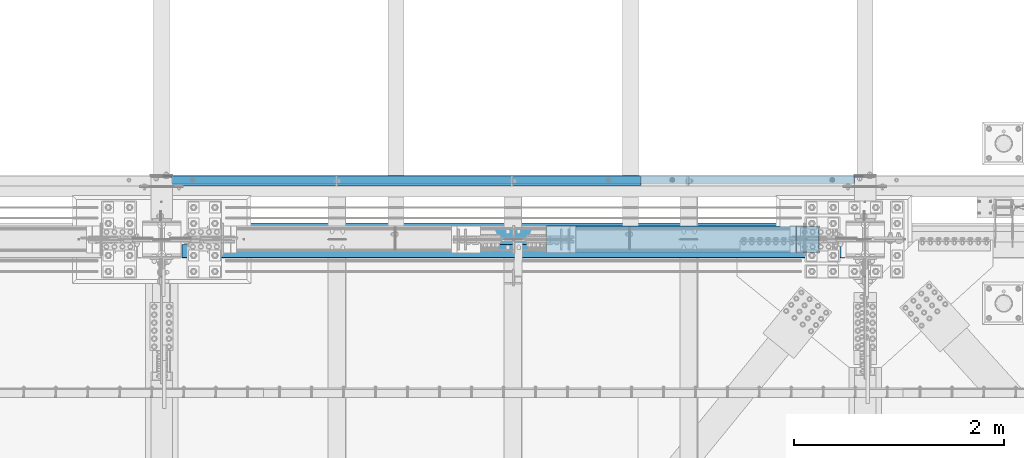
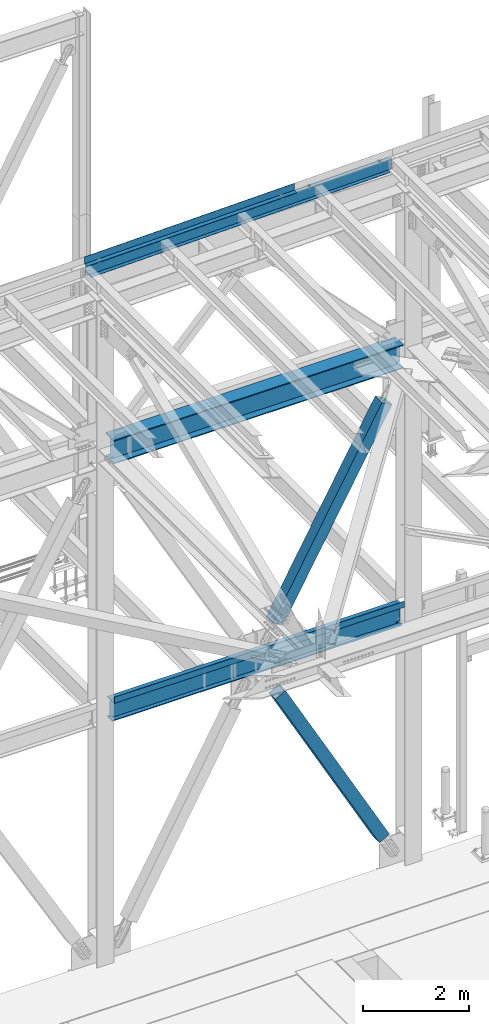
# One storey, part 1919 of 3843: 5 beams, 2 members, 5 elements without a shape of their own.
"""IFC2X3 building model written with IfcOpenShell, lengths in millimetres."""

from ifc_helpers import new_model, si_unit, frame, origin_with_axes, place, context, subcontext, project, spatial, faceted_brep, material, type_object, element, aggregate, save


model = new_model("IFC2X3")

# Units and contexts
model_context = context("Model", 3, precision=1e-05, world=origin_with_axes())
body_context = subcontext(model_context, "Body", "Model", "MODEL_VIEW")
ifc_project = project(units=[si_unit("LENGTHUNIT", "METRE", prefix="MILLI"), si_unit("AREAUNIT", "SQUARE_METRE"), si_unit("VOLUMEUNIT", "CUBIC_METRE"), si_unit("MASSUNIT", "GRAM", prefix="KILO"), si_unit("TIMEUNIT", "SECOND"), si_unit("PLANEANGLEUNIT", "RADIAN"), si_unit("SOLIDANGLEUNIT", "STERADIAN"), si_unit("THERMODYNAMICTEMPERATUREUNIT", "DEGREE_CELSIUS"), si_unit("LUMINOUSINTENSITYUNIT", "LUMEN")], contexts=[model_context])

# Site, building, storey
site_placement = place(None, origin_with_axes())
site = spatial("IfcSite", under=ifc_project, at=site_placement, CompositionType="ELEMENT")
building_placement = place(site_placement, origin_with_axes())
building = spatial("IfcBuilding", under=site, at=building_placement, Name="Undefined", CompositionType="ELEMENT")
storey_placement = place(building_placement, origin_with_axes())
storey = spatial("IfcBuildingStorey", under=building, at=storey_placement, Name="Undefined", CompositionType="ELEMENT", Elevation=0.0)

# Assembly, beams
assembly_1_placement = place(storey_placement, origin_with_axes())
assembly_1 = element("IfcElementAssembly", 1, at=assembly_1_placement, inside=storey, Name="CHANNEL", AssemblyPlace="NOTDEFINED", PredefinedType="RIGID_FRAME")
ifc_material_1 = material(Name="STEEL/A572-50")
beam_type_1 = type_object("IfcBeamType", Name="C12X20.7", PredefinedType="NOTDEFINED")
beam_1_placement = place(assembly_1_placement, frame((55927.4421007535, 92786.199998456, 45986.575723427), z_axis=(-0.0211520980073474, 0.0, 0.999776269347241), x_axis=(0.999776270257024, 0.0, 0.0211520550054619)))
beam_1 = element("IfcBeam", 2, at=beam_1_placement, type_object=beam_type_1, material=ifc_material_1, Name="CHANNEL", ObjectType="C12X20.7", context=body_context, shape_type="Brep", body=[
    faceted_brep([(15.8751814754869, 30.1625000000058, -127.000000049156), (15.8750003662499, 38.1000000000058, -127.000000023749), (85.725000532555, 38.1000000000058, -127.000000023691), (85.725000532555, 30.1625000000058, -127.000000023691), (90.5850800505723, 38.1000000000058, -127.966729946267), (90.5850800505723, 30.1625000000058, -127.966729946267), (94.7052565187187, 38.1000000000058, -130.719743846734), (94.7052565187187, 30.1625000000058, -130.719743846734), (97.4582704191853, 38.1000000000058, -134.839920314858), (97.458270419178, 30.1625000000058, -134.674927499669), (98.4250003417692, 1.00112811196595e-06, -139.699999832876), (98.4250003417692, 38.1000000000058, -139.699999832876), (98.4250003417837, 38.1000000000058, -152.399999999638), (98.4250003417837, -38.1000000000058, -152.399999999638), (98.4250003417765, -38.1000000000058, -146.047459999652), (6608.67788717964, -38.1000000000058, 146.047460006397), (6608.67788717963, -38.1000000000058, 152.400000006382), (98.4250003414782, -38.1000000000058, 152.399999999863), (98.4250003414927, -38.1000000000058, 146.047459999871), (6608.67788717963, 38.1000000000058, 152.400000006382), (98.4250003414782, 38.1000000000058, 152.399999999863), (85.7250005323076, 30.1625000000058, 126.99999997508), (85.7250005323076, 38.1000000000058, 126.99999997508), (15.8750006201954, 38.1000000000058, 126.999999975014), (15.8751845281877, 30.1625000000058, 126.999999949614), (90.5850800503176, 30.1625000000058, 127.966729897671), (90.5850800503176, 38.1000000000058, 127.966729897671), (94.7052565184495, 30.1625000000058, 130.719743798138), (94.7052565184495, 38.1000000000058, 130.719743798138), (97.4582704189161, 30.1625000000058, 134.674927499887), (97.4582704189233, 38.1000000000058, 134.839920266269), (98.4250003414927, 1.29402906168252e-06, 139.699999784301), (98.4250003414927, 38.1000000000058, 139.699999784301), (6609.64461710223, 30.1625000000058, 134.674927506407), (6608.67788717964, 1.15988950710744e-06, 139.699999813165), (6608.67788717964, 38.1000000000058, 139.699999813165), (6609.64461710223, 38.1000000000058, 134.83992029514), (6612.39763100271, 30.1625000000058, 130.719743827016), (6612.39763100271, 38.1000000000058, 130.719743827016), (6616.51780747084, 30.1625000000058, 127.966729926549), (6616.51780747084, 38.1000000000058, 127.966729926549), (6621.37788698886, 30.1625000000058, 127.00000000398), (6621.37788698886, 38.1000000000058, 127.00000000398), (6691.22583270017, 30.1625000000058, 127.000000004038), (6691.22559387093, 38.1000000000058, 127.000000004038), (6691.22583243326, 30.1625000000058, 114.299999315597), (6691.22582758687, 30.1625000000058, -116.300000677649), (6691.22582736199, 30.1625000000058, -126.999999994725), (6691.22558853275, 38.1000000000058, -126.999999994725), (6621.37788698912, 30.1625000000058, -126.999999994805), (6621.37788698912, 38.1000000000058, -126.999999994805), (6616.51780747109, 30.1625000000058, -127.966729917382), (6616.51780747109, 38.1000000000058, -127.966729917382), (6612.39763100295, 30.1625000000058, -130.719743817848), (6612.39763100295, 38.1000000000058, -130.719743817848), (6609.64461710249, 30.1625000000058, -134.674927493157), (6609.64461710249, 38.1000000000058, -134.839920285995), (6608.67788717993, 1.13523856271058e-06, -139.699999804012), (6608.67788717993, 38.1000000000058, -139.699999804012), (6608.67788717993, -38.1000000000058, -146.047459993133), (6608.67788717994, -38.1000000000058, -152.399999993126), (6608.67788717994, 38.1000000000058, -152.399999993126), (15.8751816040894, 30.1625000000058, -116.299999637456), (15.8751843755526, 30.1625000000058, 114.300000367155)], [[[0, 1, 2, 3]], [[3, 2, 4, 5]], [[5, 4, 6, 7]], [[7, 6, 8, 9]], [[10, 11, 12, 13, 14]], [[9, 8, 11, 10]], [[15, 16, 17, 18]], [[16, 19, 20, 17]], [[21, 22, 23, 24]], [[25, 26, 22, 21]], [[27, 28, 26, 25]], [[29, 30, 28, 27]], [[31, 32, 30, 29]], [[17, 20, 32, 31, 18]], [[29, 33, 34, 15, 18, 31]], [[16, 15, 34, 35, 19]], [[33, 36, 35, 34]], [[37, 38, 36, 33]], [[39, 40, 38, 37]], [[41, 42, 40, 39]], [[43, 44, 42, 41]], [[44, 43, 45, 46, 47, 48]], [[47, 49, 50, 48]], [[51, 52, 50, 49]], [[53, 54, 52, 51]], [[55, 56, 54, 53]], [[57, 58, 56, 55]], [[59, 60, 61, 58, 57]], [[60, 59, 14, 13]], [[61, 60, 13, 12]], [[6, 4, 2, 1, 23, 22, 26, 28, 30, 32, 20, 19, 35, 36, 38, 40, 42, 44, 48, 50, 52, 54, 56, 58, 61, 12, 11, 8]], [[62, 63, 24, 23, 1, 0]], [[55, 53, 51, 49, 47, 46, 45, 43, 41, 39, 37, 33, 29, 27, 25, 21, 24, 63, 62, 0, 3, 5, 7, 9]], [[59, 57, 55, 9, 10, 14]]]),
])
ifc_material_2 = material(Name="STEEL/A36")
beam_type_2 = type_object("IfcBeamType", PredefinedType="NOTDEFINED")
beam_2_placement = place(assembly_1_placement, frame((58209.6399109012, 92722.6999533711, 46190.469612909), z_axis=(0.999776270257024, 0.0, 0.0211520550054619), x_axis=(0.0, 1.0, 0.0)))
beam_2 = element("IfcBeam", 3, at=beam_2_placement, type_object=beam_type_2, material=ifc_material_2, Name="BENT_PLATE", context=body_context, shape_type="Brep", body=[
    faceted_brep([(0.0, 0.0, -2286.0), (3.49245965480804e-10, 3.17499999771098, -2282.82500002157), (95.2499986609328, 3.17500004237809, -2282.82500002194), (98.4249986544455, 9.08548827283084e-08, -2285.99999999666), (95.249998597661, 161.925001390824, -2282.82500002276), (98.4249985899223, 161.92500139217, -2285.99999999706), (95.2499986633193, 3.17500004695466, 2285.99999999594), (95.2499985934701, 161.925001402509, 2285.99999999556), (5.82076609134674e-11, -3.17499999999563, -2286.0), (5.82076609134674e-11, -3.17499999999563, 2286.0), (-4.36557456851006e-11, 3.17499999998836, 2286.0), (101.599998662903, -3.17499995464459, -2285.99999999667), (101.600001545667, -3.17499906016019, 2285.99999999734), (101.599998593476, 161.925001405216, 2285.99999999553), (101.599998596852, 161.925001394004, -2285.99999999707)], [[[0, 1, 2, 3]], [[3, 2, 4, 5]], [[6, 7, 4, 2]], [[8, 9, 10, 1, 0]], [[10, 6, 2, 1]], [[9, 8, 11, 12]], [[6, 10, 9, 12, 13, 7]], [[12, 11, 14, 13]], [[14, 11, 8, 0, 3, 5]], [[7, 13, 14, 5, 4]]]),
])
aggregate(assembly_1, [beam_1, beam_2])

# Assembly, beam
assembly_2_placement = place(storey_placement, origin_with_axes())
assembly_2 = element("IfcElementAssembly", 4, at=assembly_2_placement, inside=storey, Name="BEAM", AssemblyPlace="NOTDEFINED", PredefinedType="RIGID_FRAME")
ifc_material_3 = material(Name="STEEL/A992")
beam_type_3 = type_object("IfcBeamType", Name="W21X101", PredefinedType="NOTDEFINED")
beam_3_placement = place(assembly_2_placement, frame((55930.7999983949, 92214.6999999811, 42197.337498318), z_axis=(0.0, 0.0, 1.0), x_axis=(1.0, 0.0, 0.0)))
beam_3 = element("IfcBeam", 5, at=beam_3_placement, type_object=beam_type_3, material=ifc_material_3, Name="BEAM", ObjectType="W21X101", context=body_context, shape_type="Brep", body=[
    faceted_brep([(6511.925, -6.35000000000582, 215.900000000001), (6511.925, -6.35000000000582, -215.900000000001), (6504.59265187845, 6.35000000000582, -215.900000000001), (6504.59265187845, 6.35000000000582, 215.900000000001), (193.675000000003, 155.575000000001, 250.824999999997), (205.589601116109, 155.575000000001, 271.462500000001), (6500.01039888389, 155.575000000001, 271.462500000001), (6511.925, 155.575000000001, 250.824999999997), (193.675000000003, 6.35000000000036, 250.824999999997), (6511.925, 6.34999999999854, 250.824999999997), (205.589615981677, -155.575000000001, -250.824999999997), (193.675000000003, -155.575000000001, -271.462500000001), (6511.925, -155.575000000001, -271.462500000001), (6500.01038401834, -155.575000000001, -250.824999999997), (193.675000000003, 155.575000000001, -271.462500000001), (6511.925, 155.575000000001, -271.462500000001), (205.589615981677, 155.575000000001, -250.824999999997), (6500.01038401834, 155.575000000001, -250.824999999997), (205.589615981677, 6.35000000000036, -250.824999999997), (6500.01038401834, 6.34999999999854, -250.824999999997), (6430.04956922777, -6.34999999999854, -217.357163726287), (6430.04956922777, 6.34999999999854, -217.357163726287), (6435.11273441852, 6.34999999999854, -215.900000000001), (6435.11273441852, -6.34999999999854, -215.900000000001), (6426.53556119222, -6.34999999999854, -221.282812131343), (6426.53556119222, 6.34999999999854, -221.282812131343), (6425.64587781809, -6.34999999999854, -226.475829690324), (6425.64587781809, 6.34999999999854, -226.475829690324), (6427.65273210119, -6.34999999999854, -231.347328818971), (6427.65273210119, 6.34999999999854, -231.347328818971), (6431.94209456491, -6.34999999999854, -234.406795689014), (6431.94209456491, 6.34999999999854, -234.406795689014), (6477.32699999998, -6.34999999999854, -250.428), (6477.32699999998, 6.34999999999854, -250.428), (6499.78119200916, -6.34999999999854, -250.428), (6499.78119200916, 6.34999999999854, -250.428), (6500.01038401834, -6.34999999999854, -250.824999999997), (205.589615981677, -6.35000000000036, -250.824999999997), (205.818807990843, -6.35000000000036, -250.428), (205.818807990843, 6.35000000000036, -250.428), (228.27300000003, -6.35000000000036, -250.428), (228.27300000003, 6.35000000000036, -250.428), (273.657905435088, -6.35000000000036, -234.406795689014), (273.657905435088, 6.35000000000036, -234.406795689014), (277.94726789881, -6.35000000000036, -231.347328818971), (277.94726789881, 6.35000000000036, -231.347328818971), (279.954122181924, -6.35000000000036, -226.475829690324), (279.954122181924, 6.35000000000036, -226.475829690324), (279.064438807793, -6.35000000000036, -221.282812131343), (279.064438807793, 6.35000000000036, -221.282812131343), (275.550430772229, -6.35000000000036, -217.357163726287), (275.550430772229, 6.35000000000036, -217.357163726287), (270.487265581483, -6.35000000000036, -215.900000000001), (270.487265581483, 6.35000000000036, -215.900000000001), (193.674999999996, -6.35000000000582, -215.900000000001), (201.007348416882, 6.35000000000582, -215.900000000001), (201.007348416882, 6.35000000000582, 215.900000000001), (193.674999999996, -6.35000000000582, 215.900000000001), (270.814265581474, -6.35000000000036, 215.900000000001), (270.814265581474, 6.35000000000036, 215.900000000001), (275.877430772234, -6.35000000000036, 217.357163726287), (275.877430772234, 6.35000000000036, 217.357163726287), (279.391438807783, -6.35000000000036, 221.282812131351), (279.391438807783, 6.35000000000036, 221.282812131351), (280.281122181914, -6.35000000000036, 226.475829690324), (280.281122181914, 6.35000000000036, 226.475829690324), (278.274267898814, -6.35000000000036, 231.347328818971), (278.274267898814, 6.35000000000036, 231.347328818971), (273.984905435093, -6.35000000000036, 234.406795689014), (273.984905435093, 6.35000000000036, 234.406795689014), (228.60000000002, -6.35000000000036, 250.428), (228.60000000002, 6.35000000000036, 250.428), (193.675000000003, -6.35000000000036, 250.428), (193.675000000003, 6.35000000000036, 250.428), (193.675000000003, -6.35000000000036, 250.824999999997), (205.589601116109, -155.575000000001, 271.462500000001), (193.675000000003, -155.575000000001, 250.824999999997), (6511.925, -6.34999999999854, 250.824999999997), (6511.925, -155.575000000001, 250.824999999997), (6500.01039888389, -155.575000000001, 271.462500000001), (6511.925, -6.34999999999854, 250.428), (6511.925, 6.34999999999854, 250.428), (6476.99999999999, -6.34999999999854, 250.428), (6476.99999999999, 6.34999999999854, 250.428), (6431.61509456491, -6.34999999999854, 234.406795689014), (6431.61509456491, 6.34999999999854, 234.406795689014), (6427.32573210119, -6.34999999999854, 231.347328818971), (6427.32573210119, 6.34999999999854, 231.347328818971), (6425.31887781809, -6.34999999999854, 226.475829690324), (6425.31887781809, 6.34999999999854, 226.475829690324), (6426.20856119222, -6.34999999999854, 221.282812131351), (6426.20856119222, 6.34999999999854, 221.282812131351), (6429.72256922777, -6.34999999999854, 217.357163726287), (6429.72256922777, 6.34999999999854, 217.357163726287), (6434.78573441852, -6.34999999999854, 215.900000000001), (6434.78573441852, 6.34999999999854, 215.900000000001)], [[[0, 1, 2, 3]], [[4, 5, 6, 7]], [[8, 4, 7, 9]], [[10, 11, 12, 13]], [[11, 14, 15, 12]], [[14, 16, 17, 15]], [[16, 18, 19, 17]], [[20, 21, 22, 23]], [[24, 25, 21, 20]], [[26, 27, 25, 24]], [[28, 29, 27, 26]], [[30, 31, 29, 28]], [[32, 33, 31, 30]], [[33, 32, 34, 35]], [[12, 15, 17, 19, 35, 34, 36, 13]], [[37, 10, 13, 36]], [[38, 39, 18, 16, 14, 11, 10, 37]], [[40, 41, 39, 38]], [[42, 43, 41, 40]], [[44, 45, 43, 42]], [[46, 47, 45, 44]], [[48, 49, 47, 46]], [[50, 51, 49, 48]], [[52, 53, 51, 50]], [[53, 52, 54, 55]], [[56, 55, 54, 57]], [[58, 59, 56, 57]], [[60, 61, 59, 58]], [[62, 63, 61, 60]], [[64, 65, 63, 62]], [[66, 67, 65, 64]], [[68, 69, 67, 66]], [[70, 71, 69, 68]], [[71, 70, 72, 73]], [[73, 72, 74, 8]], [[75, 5, 4, 8, 74, 76]], [[76, 74, 77, 78]], [[75, 76, 78, 79]], [[5, 75, 79, 6]], [[78, 77, 9, 7, 6, 79]], [[80, 81, 9, 77]], [[82, 83, 81, 80]], [[84, 85, 83, 82]], [[86, 87, 85, 84]], [[88, 89, 87, 86]], [[90, 91, 89, 88]], [[92, 93, 91, 90]], [[94, 95, 93, 92]], [[95, 94, 0, 3]], [[22, 21, 25, 27, 29, 31, 33, 35, 19, 18, 39, 41, 43, 45, 47, 49, 51, 53, 55, 56, 59, 61, 63, 65, 67, 69, 71, 73, 8, 9, 81, 83, 85, 87, 89, 91, 93, 95, 3, 2]], [[23, 22, 2, 1]], [[94, 92, 90, 88, 86, 84, 82, 80, 77, 74, 72, 70, 68, 66, 64, 62, 60, 58, 57, 54, 52, 50, 48, 46, 44, 42, 40, 38, 37, 36, 34, 32, 30, 28, 26, 24, 20, 23, 1, 0]]]),
])
aggregate(assembly_2, [beam_3])

assembly_3_placement = place(storey_placement, origin_with_axes())
assembly_3 = element("IfcElementAssembly", 6, at=assembly_3_placement, inside=storey, Name="BEAM", AssemblyPlace="NOTDEFINED", PredefinedType="RIGID_FRAME")
beam_type_4 = type_object("IfcBeamType", Name="W18X65", PredefinedType="NOTDEFINED")
beam_4_placement = place(assembly_3_placement, frame((55930.8, 92214.7, 36202.9375), z_axis=(0.0, 0.0, 1.0), x_axis=(1.0, 0.0, 0.0)))
beam_4 = element("IfcBeam", 7, at=beam_4_placement, type_object=beam_type_4, material=ifc_material_3, Name="BEAM", ObjectType="W18X65", context=body_context, shape_type="Brep", body=[
    faceted_brep([(6511.925, 5.55624999999418, 179.387499999997), (6505.575, -5.55624999999418, 179.387499999997), (6505.575, -5.55624999999418, -179.387499999997), (6511.925, 5.55624999999418, -179.387499999997), (193.674999999996, 96.8374999999942, 214.3125), (204.673581529503, 96.8374999999942, 233.362500000003), (6500.9264184705, 96.8374999999942, 233.362500000003), (6511.925, 96.8374999999942, 214.3125), (193.674999999996, 5.55624999999418, 214.3125), (6511.925, 5.55624999999418, 214.3125), (204.673597538524, -96.8374999999942, -214.3125), (193.674999999996, -96.8374999999942, -233.362500000003), (6511.925, -96.8374999999942, -233.362500000003), (6500.92640246147, -96.8374999999942, -214.3125), (193.674999999996, 96.8374999999942, -233.362500000003), (6511.925, 96.8374999999942, -233.362500000003), (204.673597538524, 96.8374999999942, -214.3125), (6500.92640246147, 96.8374999999942, -214.3125), (204.673597538524, 5.55624999999418, -214.3125), (6500.92640246147, 5.55624999999418, -214.3125), (6430.96556922777, -5.55624999999418, -180.844663726282), (6430.96556922777, 5.55624999999418, -180.844663726282), (6436.02873441853, 5.55624999999418, -179.387499999997), (6436.02873441853, -5.55624999999418, -179.387499999997), (6427.45156119222, -5.55624999999418, -184.770312131339), (6427.45156119222, 5.55624999999418, -184.770312131339), (6426.56187781809, -5.55624999999418, -189.963329690319), (6426.56187781809, 5.55624999999418, -189.963329690319), (6428.56873210119, -5.55624999999418, -194.834828818966), (6428.56873210119, 5.55624999999418, -194.834828818966), (6432.85809456492, -5.55624999999418, -197.89429568901), (6432.85809456492, 5.55624999999418, -197.89429568901), (6478.24299999999, -5.55624999999418, -213.915500000003), (6478.24299999999, 5.55624999999418, -213.915500000003), (6500.69720123074, -5.55624999999418, -213.915500000003), (6500.69720123074, 5.55624999999418, -213.915500000003), (6500.92640246147, -5.55624999999418, -214.3125), (204.673597538524, -5.55624999999418, -214.3125), (204.902798769261, -5.55624999999418, -213.915500000003), (204.902798769261, 5.55624999999418, -213.915500000003), (227.357000000004, -5.55624999999418, -213.915500000003), (227.357000000004, 5.55624999999418, -213.915500000003), (272.741905435083, -5.55624999999418, -197.89429568901), (272.741905435083, 5.55624999999418, -197.89429568901), (277.031267898805, -5.55624999999418, -194.834828818966), (277.031267898805, 5.55624999999418, -194.834828818966), (279.038122181912, -5.55624999999418, -189.963329690319), (279.038122181912, 5.55624999999418, -189.963329690319), (278.148438807781, -5.55624999999418, -184.770312131339), (278.148438807781, 5.55624999999418, -184.770312131339), (274.634430772225, -5.55624999999418, -180.844663726282), (274.634430772225, 5.55624999999418, -180.844663726282), (269.571265581471, -5.55624999999418, -179.387499999997), (269.571265581471, 5.55624999999418, -179.387499999997), (200.024999999994, -5.55624999999418, -179.387499999997), (193.674999999996, 5.55624999999418, -179.387499999997), (200.024999999994, -5.55625000000873, 179.387499999997), (193.674999999996, 5.55624999999418, 179.387499999997), (270.814265581474, -5.55624999999418, 179.387499999997), (270.814265581474, 5.55624999999418, 179.387499999997), (275.877430772227, -5.55624999999418, 180.844663726282), (275.877430772227, 5.55624999999418, 180.844663726282), (279.391438807776, -5.55624999999418, 184.770312131339), (279.391438807776, 5.55624999999418, 184.770312131339), (280.281122181907, -5.55624999999418, 189.963329690319), (280.281122181907, 5.55624999999418, 189.963329690319), (278.274267898807, -5.55624999999418, 194.834828818966), (278.274267898807, 5.55624999999418, 194.834828818966), (273.984905435085, -5.55624999999418, 197.89429568901), (273.984905435085, 5.55624999999418, 197.89429568901), (228.600000000006, -5.55624999999418, 213.915500000003), (228.600000000006, 5.55624999999418, 213.915500000003), (193.674999999996, -5.55624999999418, 213.915500000003), (193.674999999996, 5.55624999999418, 213.915500000003), (193.674999999996, -5.55624999999418, 214.3125), (204.673581529503, -96.8374999999942, 233.362500000003), (193.674999999996, -96.8374999999942, 214.3125), (6511.925, -5.55624999999418, 214.3125), (6511.925, -96.8374999999942, 214.3125), (6500.9264184705, -96.8374999999942, 233.362500000003), (6511.925, -5.55624999999418, 213.915500000003), (6511.925, 5.55624999999418, 213.915500000003), (6476.99999999999, -5.55624999999418, 213.915500000003), (6476.99999999999, 5.55624999999418, 213.915500000003), (6431.61509456491, -5.55624999999418, 197.89429568901), (6431.61509456491, 5.55624999999418, 197.89429568901), (6427.32573210119, -5.55624999999418, 194.834828818966), (6427.32573210119, 5.55624999999418, 194.834828818966), (6425.31887781809, -5.55624999999418, 189.963329690319), (6425.31887781809, 5.55624999999418, 189.963329690319), (6426.20856119222, -5.55624999999418, 184.770312131339), (6426.20856119222, 5.55624999999418, 184.770312131339), (6429.72256922777, -5.55624999999418, 180.844663726282), (6429.72256922777, 5.55624999999418, 180.844663726282), (6434.78573441852, -5.55624999999418, 179.387499999997), (6434.78573441852, 5.55624999999418, 179.387499999997)], [[[0, 1, 2, 3]], [[4, 5, 6, 7]], [[8, 4, 7, 9]], [[10, 11, 12, 13]], [[11, 14, 15, 12]], [[14, 16, 17, 15]], [[16, 18, 19, 17]], [[20, 21, 22, 23]], [[24, 25, 21, 20]], [[26, 27, 25, 24]], [[28, 29, 27, 26]], [[30, 31, 29, 28]], [[32, 33, 31, 30]], [[33, 32, 34, 35]], [[12, 15, 17, 19, 35, 34, 36, 13]], [[37, 10, 13, 36]], [[38, 39, 18, 16, 14, 11, 10, 37]], [[40, 41, 39, 38]], [[42, 43, 41, 40]], [[44, 45, 43, 42]], [[46, 47, 45, 44]], [[48, 49, 47, 46]], [[50, 51, 49, 48]], [[52, 53, 51, 50]], [[53, 52, 54, 55]], [[56, 57, 55, 54]], [[58, 59, 57, 56]], [[60, 61, 59, 58]], [[62, 63, 61, 60]], [[64, 65, 63, 62]], [[66, 67, 65, 64]], [[68, 69, 67, 66]], [[70, 71, 69, 68]], [[71, 70, 72, 73]], [[73, 72, 74, 8]], [[75, 5, 4, 8, 74, 76]], [[76, 74, 77, 78]], [[75, 76, 78, 79]], [[5, 75, 79, 6]], [[78, 77, 9, 7, 6, 79]], [[80, 81, 9, 77]], [[82, 83, 81, 80]], [[84, 85, 83, 82]], [[86, 87, 85, 84]], [[88, 89, 87, 86]], [[90, 91, 89, 88]], [[92, 93, 91, 90]], [[94, 95, 93, 92]], [[22, 21, 25, 27, 29, 31, 33, 35, 19, 18, 39, 41, 43, 45, 47, 49, 51, 53, 55, 57, 59, 61, 63, 65, 67, 69, 71, 73, 8, 9, 81, 83, 85, 87, 89, 91, 93, 95, 0, 3]], [[23, 22, 3, 2]], [[94, 92, 90, 88, 86, 84, 82, 80, 77, 74, 72, 70, 68, 66, 64, 62, 60, 58, 56, 54, 52, 50, 48, 46, 44, 42, 40, 38, 37, 36, 34, 32, 30, 28, 26, 24, 20, 23, 2, 1]], [[95, 94, 1, 0]]]),
])

# Assembly, member
assembly_4_placement = place(storey_placement, origin_with_axes())
assembly_4 = element("IfcElementAssembly", 8, at=assembly_4_placement, inside=storey, Name="None", AssemblyPlace="NOTDEFINED", PredefinedType="RIGID_FRAME")
member_type = type_object("IfcMemberType", Name="HSS10X10X1/4", PredefinedType="NOTDEFINED")
member_1_placement = place(assembly_4_placement, frame((59709.9222494841, 92214.7, 36964.9063992894), z_axis=(0.0, -1.0, 0.0), x_axis=(0.48827172176639, 0.0, 0.872691655582477)))
member_1 = element("IfcMember", 9, at=member_1_placement, type_object=member_type, material=ifc_material_3, Name="None", ObjectType="HSS10X10X1/4", context=body_context, shape_type="Brep", body=[
    faceted_brep([(2.00088834390044e-10, 120.650000000089, -120.649999999994), (-2.03726813197136e-10, -120.650000000081, -120.649999999994), (4870.45000005738, -120.649999988149, -120.649999999994), (4870.45000005679, 120.650000012101, -120.649999999994), (-2.03726813197136e-10, -120.650000000081, 120.649999999994), (4870.45000005738, -120.649999988149, 120.649999999994), (2.00088834390044e-10, 120.650000000089, 120.649999999994), (4870.45000005679, 120.650000012101, 120.649999999994), (2.16459739021957e-10, 127.000000000087, -127.0), (2.16459739021957e-10, 127.000000000087, 127.0), (4870.45000005677, 127.000000012122, 127.0), (4870.45000005677, 127.000000012122, -127.0), (-2.14640749618411e-10, -127.00000000008, 127.0), (4870.4500000574, -126.999999988155, 127.0), (-2.14640749618411e-10, -127.00000000008, -127.0), (4870.4500000574, -126.999999988155, -127.0)], [[[0, 1, 2, 3]], [[1, 4, 5, 2]], [[4, 6, 7, 5]], [[6, 0, 3, 7]], [[8, 9, 10, 11]], [[9, 12, 13, 10]], [[12, 14, 15, 13]], [[14, 8, 11, 15]], [[13, 15, 11, 10], [5, 7, 3, 2]], [[14, 12, 9, 8], [6, 4, 1, 0]]]),
])
aggregate(assembly_4, [member_1])

assembly_5_placement = place(storey_placement, origin_with_axes())
assembly_5 = element("IfcElementAssembly", 10, at=assembly_5_placement, inside=storey, Name="None", AssemblyPlace="NOTDEFINED", PredefinedType="RIGID_FRAME")
member_2_placement = place(assembly_5_placement, frame((62032.7821408967, 92214.7, 31229.1567433966), z_axis=(0.0, 1.0, 0.0), x_axis=(-0.483755372180955, 0.0, 0.875203256327389)))
member_2 = element("IfcMember", 11, at=member_2_placement, type_object=member_type, material=ifc_material_3, Name="None", ObjectType="HSS10X10X1/4", context=body_context, shape_type="Brep", body=[
    faceted_brep([(2.00088834390044e-10, 120.650000000089, -120.649999999994), (-2.03726813197136e-10, -120.650000000081, -120.649999999994), (4679.95000001111, -120.650000007008, -120.649999999994), (4679.95000001146, 120.649999992798, -120.649999999994), (-2.03726813197136e-10, -120.650000000081, 120.649999999994), (4679.95000001111, -120.650000007008, 120.649999999994), (2.00088834390044e-10, 120.650000000089, 120.649999999994), (4679.95000001146, 120.649999992798, 120.649999999994), (2.16459739021957e-10, 127.000000000087, -127.0), (2.16459739021957e-10, 127.000000000087, 127.0), (4679.95000001148, 126.999999992797, 127.0), (4679.95000001148, 126.999999992797, -127.0), (-2.14640749618411e-10, -127.00000000008, 127.0), (4679.9500000111, -127.000000007007, 127.0), (-2.14640749618411e-10, -127.00000000008, -127.0), (4679.9500000111, -127.000000007007, -127.0)], [[[0, 1, 2, 3]], [[1, 4, 5, 2]], [[4, 6, 7, 5]], [[6, 0, 3, 7]], [[8, 9, 10, 11]], [[9, 12, 13, 10]], [[12, 14, 15, 13]], [[14, 8, 11, 15]], [[13, 15, 11, 10], [5, 7, 3, 2]], [[14, 12, 9, 8], [6, 4, 1, 0]]]),
])
aggregate(assembly_5, [member_2])

# Beam
beam_type_5 = type_object("IfcBeamType", PredefinedType="NOTDEFINED")
beam_5_placement = place(assembly_3_placement, frame((59283.6, 92168.662, 36439.475), z_axis=(-1.0, 0.0, 0.0), x_axis=(0.0, -1.0, 0.0)))
beam_5 = element("IfcBeam", 12, at=beam_5_placement, type_object=beam_type_5, material=ifc_material_2, Name="BENT_PLATE", context=body_context, shape_type="Brep", body=[
    faceted_brep([(125.411993408168, -3.17500000000291, -3122.61250000003), (125.411993408197, 3.17500000000291, -3122.61250000003), (125.411993408197, 3.17500000000291, -3159.125), (125.411993408183, -3.17500000000291, -3159.125), (0.0, -3.17500000000291, -3122.61250000003), (0.0, 3.17500000000291, -3122.61250000003), (125.411993408197, 3.17500000000291, 3159.125), (0.0, 3.17500000000291, 3159.125), (0.0, -3.17500000000291, 3159.125), (131.761993408203, -3.17500000000291, 3159.125), (131.761993408203, 136.524996948239, 3159.125), (125.411993408197, 136.524996948239, 3159.125), (131.761993408203, -3.17500000000291, -3159.125), (131.761993408203, 136.524996948239, -3159.125), (125.411993408197, 136.524996948239, -3159.125), (125.411993408197, 136.524996948239, -3122.61250000003)], [[[0, 1, 2, 3]], [[4, 5, 1, 0]], [[6, 7, 8, 9, 10, 11]], [[9, 12, 13, 10]], [[14, 13, 12, 3, 2]], [[11, 10, 13, 14, 15]], [[2, 1, 6, 11, 15, 14]], [[7, 6, 1, 5]], [[8, 7, 5, 4]], [[12, 9, 8, 4, 0, 3]]]),
])

aggregate(assembly_3, [beam_5, beam_4])

save(model, "model.ifc")
